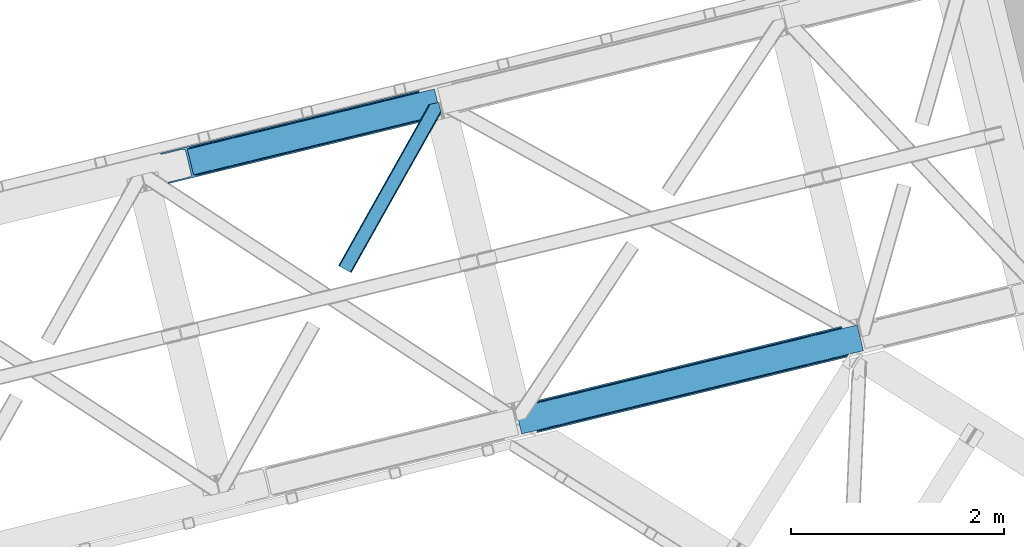
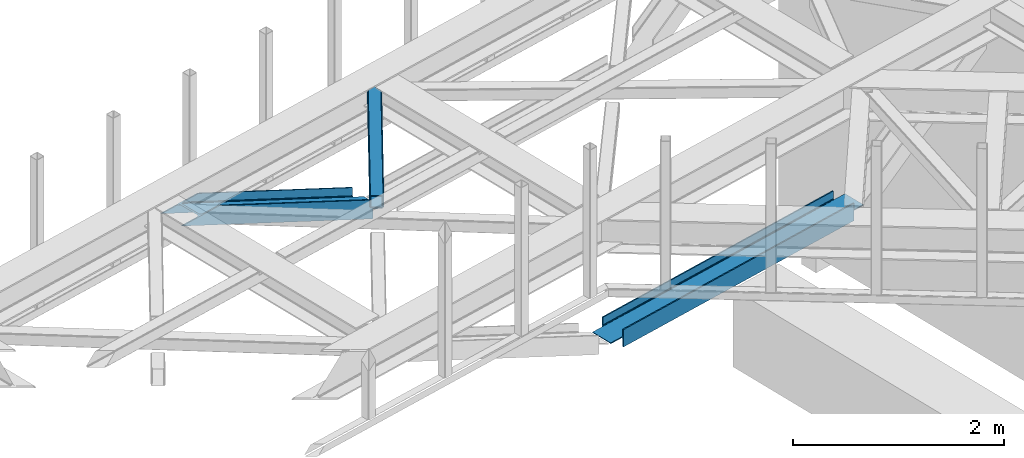
# One storey, part 57 of 66: 3 members.
"""IFC4 building model written with IfcOpenShell, lengths in millimetres."""

import ifcopenshell
import ifcopenshell.guid

model = None  # the IFC model being written
_history = None  # IfcOwnerHistory: only IFC2X3 demands one
_inside = {}  # id of a spatial element -> (the spatial element, [elements in it])
_under = {}  # id of a project, library or spatial element -> (it, [spatial elements below it])
_declared = {}  # id of a project -> (the project, [libraries it declares])
_typed = {}  # id of a type object -> (the type object, [elements of that type])
_made_of = {}  # id of a material, layer set ... -> (it, [elements and type objects made of it])


def new_model(schema):
    """Start an empty IFC model of exactly this schema.

    Asked for "IFC4X3", IfcOpenShell would pick the latest addendum, in which some entities
    have other attributes; the version numbers below select the first issue.
    IFC2X3 requires an IfcOwnerHistory on every rooted entity: one is made here for all.
    """
    global model, _history
    if schema == "IFC4X3":
        model = ifcopenshell.file(schema_version=(4, 3, 0, 0))
    else:
        model = ifcopenshell.file(schema=schema)
    _inside.clear()
    _under.clear()
    _declared.clear()
    _typed.clear()
    _made_of.clear()
    _history = None
    if model.schema == "IFC2X3":
        org = make("IfcOrganization", Name="unknown")
        user = make(
            "IfcPersonAndOrganization",
            ThePerson=make("IfcPerson", FamilyName="unknown"),
            TheOrganization=org,
        )
        app = make(
            "IfcApplication",
            ApplicationDeveloper=org,
            Version="unknown",
            ApplicationFullName="unknown",
            ApplicationIdentifier="unknown",
        )
        _history = make(
            "IfcOwnerHistory",
            OwningUser=user,
            OwningApplication=app,
            ChangeAction="ADDED",
            CreationDate=0,
        )
    return model


def make(cls, **values):
    """One entity of the class cls with the attributes given. An attribute that is None is left unset."""
    return model.create_entity(
        cls, **{name: value for name, value in values.items() if value is not None}
    )


def entity(cls, *values):
    """Any entity or typed value of the class cls, its attributes in the order of the schema. None: left unset."""
    e = model.create_entity(cls)
    for i, value in enumerate(values):
        if value is not None:
            e[i] = value
    return e


def rooted(cls, **values):
    """An entity with a GlobalId (a new one), such as an element, a storey or a relation."""
    return make(cls, GlobalId=ifcopenshell.guid.new(), OwnerHistory=_history, **values)


def si_unit(unit_type, name, prefix=None):
    """IfcSIUnit, for example si_unit("LENGTHUNIT", "METRE", prefix="MILLI")."""
    return make("IfcSIUnit", UnitType=unit_type, Prefix=prefix, Name=name)


def converted_unit(unit_type, name, factor, base, dimensions=None, offset=None):
    """IfcConversionBasedUnit, such as the inch: factor (a typed value) times the base unit."""
    return make(
        "IfcConversionBasedUnit"
        if offset is None
        else "IfcConversionBasedUnitWithOffset",
        ConversionOffset=offset,
        Dimensions=None
        if dimensions is None
        else entity("IfcDimensionalExponents", *dimensions),
        UnitType=unit_type,
        Name=name,
        ConversionFactor=make(
            "IfcMeasureWithUnit", ValueComponent=factor, UnitComponent=base
        ),
    )


def derived_unit(unit_type, elements):
    """IfcDerivedUnit: a product of units, each with its exponent."""
    return make(
        "IfcDerivedUnit",
        Elements=[
            make("IfcDerivedUnitElement", Unit=unit, Exponent=power)
            for unit, power in elements
        ],
        UnitType=unit_type,
    )


def assignment(units):
    """IfcUnitAssignment: the units of a project."""
    return None if units is None else make("IfcUnitAssignment", Units=units)


def point(xyz):
    """IfcCartesianPoint."""
    return None if xyz is None else make("IfcCartesianPoint", Coordinates=xyz)


def direction(xyz):
    """IfcDirection."""
    return None if xyz is None else make("IfcDirection", DirectionRatios=xyz)


def frame(location, z_axis=None, x_axis=None):
    """IfcAxis2Placement3D, a coordinate frame: its origin and axes. An axis left out is left unset."""
    return make(
        "IfcAxis2Placement3D",
        Location=point(location),
        Axis=direction(z_axis),
        RefDirection=direction(x_axis),
    )


def origin():
    """The frame at (0, 0, 0) with its axes left unset."""
    return frame((0.0, 0.0, 0.0))


def place(relative_to, where):
    """IfcLocalPlacement: puts the frame where relative to a parent placement (None: the world)."""
    return make(
        "IfcLocalPlacement", PlacementRelTo=relative_to, RelativePlacement=where
    )


def context(
    kind, dimensions, precision=None, world=None, true_north=None, identifier=None
):
    """IfcGeometricRepresentationContext, for example the 3D "Model" context."""
    return make(
        "IfcGeometricRepresentationContext",
        ContextIdentifier=identifier,
        ContextType=kind,
        CoordinateSpaceDimension=dimensions,
        Precision=precision,
        WorldCoordinateSystem=world,
        TrueNorth=true_north,
    )


def subcontext(parent, identifier, kind, view, scale=None):
    """IfcGeometricRepresentationSubContext, for example "Body" below "Model"."""
    return make(
        "IfcGeometricRepresentationSubContext",
        ContextIdentifier=identifier,
        ContextType=kind,
        ParentContext=parent,
        TargetScale=scale,
        TargetView=view,
    )


def project(units=None, contexts=None):
    """IfcProject with its units and contexts."""
    return rooted(
        "IfcProject",
        Name="project",
        RepresentationContexts=contexts,
        UnitsInContext=assignment(units),
    )


def spatial(cls, under=None, at=None, **own):
    """A site, building, storey or space (cls), placed at a placement, below another one or the project."""
    s = rooted(cls, ObjectPlacement=at, **own)
    if under is not None:
        _under.setdefault(under.id(), (under, []))[1].append(s)
    return s


def point_list(points):
    """IfcCartesianPointList2D or 3D."""
    cls = (
        "IfcCartesianPointList2D" if len(points[0]) == 2 else "IfcCartesianPointList3D"
    )
    return make(cls, CoordList=points)


def triangles(points, corners, closed=None, point_numbers=None):
    """IfcTriangulatedFaceSet: each triangle names its three corners, points numbered from 1."""
    return make(
        "IfcTriangulatedFaceSet",
        Coordinates=point_list(points),
        Closed=closed,
        CoordIndex=corners,
        PnIndex=point_numbers,
    )


def polygons(points, faces, closed=None, point_numbers=None):
    """IfcPolygonalFaceSet: a face is its outer loop, then its inner loops; points numbered from 1."""
    made = []
    for loops in faces:
        if len(loops) == 1:
            made.append(make("IfcIndexedPolygonalFace", CoordIndex=loops[0]))
        else:
            made.append(
                make(
                    "IfcIndexedPolygonalFaceWithVoids",
                    CoordIndex=loops[0],
                    InnerCoordIndices=loops[1:],
                )
            )
    return make(
        "IfcPolygonalFaceSet",
        Coordinates=point_list(points),
        Closed=closed,
        Faces=made,
        PnIndex=point_numbers,
    )


def shape(context_of_items, identifier, shape_type, items):
    """IfcShapeRepresentation: the items that make up one representation, for example the "Body"."""
    return make(
        "IfcShapeRepresentation",
        ContextOfItems=context_of_items,
        RepresentationIdentifier=identifier,
        RepresentationType=shape_type,
        Items=items,
    )


def made_of(thing, what):
    """Note that an element or type object is made of a material, layer set ...; save() writes the relation."""
    if what is not None:
        _made_of.setdefault(what.id(), (what, []))[1].append(thing)
    return thing


def type_object(cls, material=None, **own):
    """A type object (cls), such as IfcWallType, which elements share."""
    return made_of(rooted(cls, **own), material)


def element(
    cls,
    number,
    at=None,
    inside=None,
    cuts=None,
    type_object=None,
    material=None,
    context=None,
    identifier="Body",
    shape_type=None,
    held_by="IfcProductDefinitionShape",
    body=None,
    shapes=None,
    **own,
):
    """One element of the class cls, such as IfcWall. Its Tag is "e" and its number.

    at: its placement. inside: the storey or other place that contains it. cuts: it is an
    opening in that element (IfcRelVoidsElement). A single representation is given by context,
    identifier, shape_type and body (its items); several are given by shapes. held_by: the class
    of the entity that holds the representations. save() writes the other relations.
    """
    e = rooted(cls, Tag="e%d" % number, ObjectPlacement=at, **own)
    if body is not None:
        shapes = [shape(context, identifier, shape_type, body)]
    if shapes is not None:
        e.Representation = make(held_by, Representations=shapes)
    if inside is not None:
        _inside.setdefault(inside.id(), (inside, []))[1].append(e)
    if cuts is not None:
        rooted(
            "IfcRelVoidsElement", RelatingBuildingElement=cuts, RelatedOpeningElement=e
        )
    if type_object is not None:
        _typed.setdefault(type_object.id(), (type_object, []))[1].append(e)
    return made_of(e, material)


def aggregate(whole, parts):
    """IfcRelAggregates: a whole, such as a stair, and the parts it consists of."""
    return rooted("IfcRelAggregates", RelatingObject=whole, RelatedObjects=parts)


def save(model, path):
    """Write the relations noted so far, then the file.

    IfcRelAggregates (storeys below a building ...), IfcRelContainedInSpatialStructure (elements
    in a storey), IfcRelDefinesByType, IfcRelAssociatesMaterial and IfcRelDeclares: one each for
    every whole, place, type object, material and project.
    """
    for whole, parts in _under.values():
        aggregate(whole, parts)
    for where, things in _inside.values():
        rooted(
            "IfcRelContainedInSpatialStructure",
            RelatedElements=things,
            RelatingStructure=where,
        )
    for kind, things in _typed.values():
        rooted("IfcRelDefinesByType", RelatedObjects=things, RelatingType=kind)
    for what, things in _made_of.values():
        rooted("IfcRelAssociatesMaterial", RelatedObjects=things, RelatingMaterial=what)
    for by, libraries in _declared.values():
        rooted("IfcRelDeclares", RelatingContext=by, RelatedDefinitions=libraries)
    model.write(path)


model = new_model("IFC4")

# Units and contexts
model_context = context("Model", 3, precision=0.01, world=origin(), true_north=direction((6.12303176911189e-17, 1.0)))
plan_context = context("Plan", 3, precision=0.01, world=origin(), true_north=direction((6.12303176911189e-17, 1.0)))
body_context = subcontext(model_context, "Body", "Model", "MODEL_VIEW")
ifc_project = project(units=[si_unit("LENGTHUNIT", "METRE", prefix="MILLI"), si_unit("AREAUNIT", "SQUARE_METRE"), si_unit("VOLUMEUNIT", "CUBIC_METRE"), converted_unit("PLANEANGLEUNIT", "DEGREE", entity("IfcRatioMeasure", 0.0174532925199433), si_unit("PLANEANGLEUNIT", "RADIAN"), dimensions=[0, 0, 0, 0, 0, 0, 0]), si_unit("MASSUNIT", "GRAM", prefix="KILO"), derived_unit("MASSDENSITYUNIT", [(si_unit("MASSUNIT", "GRAM", prefix="KILO"), 1), (si_unit("LENGTHUNIT", "METRE"), -3)]), derived_unit("MOMENTOFINERTIAUNIT", [(si_unit("LENGTHUNIT", "METRE"), 4)]), si_unit("TIMEUNIT", "SECOND"), si_unit("FREQUENCYUNIT", "HERTZ"), si_unit("THERMODYNAMICTEMPERATUREUNIT", "DEGREE_CELSIUS"), derived_unit("THERMALTRANSMITTANCEUNIT", [(si_unit("MASSUNIT", "GRAM", prefix="KILO"), 1), (si_unit("THERMODYNAMICTEMPERATUREUNIT", "KELVIN"), -1), (si_unit("TIMEUNIT", "SECOND"), -3)]), derived_unit("VOLUMETRICFLOWRATEUNIT", [(si_unit("LENGTHUNIT", "METRE"), 3), (si_unit("TIMEUNIT", "SECOND"), -1)]), derived_unit("MASSFLOWRATEUNIT", [(si_unit("MASSUNIT", "GRAM", prefix="KILO"), 1), (si_unit("TIMEUNIT", "SECOND"), -1)]), derived_unit("ROTATIONALFREQUENCYUNIT", [(si_unit("TIMEUNIT", "SECOND"), -1)]), si_unit("ELECTRICCURRENTUNIT", "AMPERE"), si_unit("ELECTRICVOLTAGEUNIT", "VOLT"), si_unit("POWERUNIT", "WATT"), si_unit("FORCEUNIT", "NEWTON", prefix="KILO"), si_unit("ILLUMINANCEUNIT", "LUX"), si_unit("LUMINOUSFLUXUNIT", "LUMEN"), si_unit("LUMINOUSINTENSITYUNIT", "CANDELA"), derived_unit("USERDEFINED", [(si_unit("MASSUNIT", "GRAM", prefix="KILO"), -1), (si_unit("LENGTHUNIT", "METRE"), -2), (si_unit("TIMEUNIT", "SECOND"), 3), (si_unit("LUMINOUSFLUXUNIT", "LUMEN"), 1)]), derived_unit("LINEARVELOCITYUNIT", [(si_unit("LENGTHUNIT", "METRE"), 1), (si_unit("TIMEUNIT", "SECOND"), -1)]), si_unit("PRESSUREUNIT", "PASCAL"), derived_unit("USERDEFINED", [(si_unit("LENGTHUNIT", "METRE"), -2), (si_unit("MASSUNIT", "GRAM", prefix="KILO"), 1), (si_unit("TIMEUNIT", "SECOND"), -2)]), derived_unit("LINEARFORCEUNIT", [(si_unit("MASSUNIT", "GRAM", prefix="KILO"), 1), (si_unit("LENGTHUNIT", "METRE"), 1), (si_unit("TIMEUNIT", "SECOND"), -2), (si_unit("LENGTHUNIT", "METRE"), -1)]), derived_unit("PLANARFORCEUNIT", [(si_unit("MASSUNIT", "GRAM", prefix="KILO"), 1), (si_unit("LENGTHUNIT", "METRE"), 1), (si_unit("TIMEUNIT", "SECOND"), -2), (si_unit("LENGTHUNIT", "METRE"), -2)])], contexts=[model_context, plan_context])

# Site, building, storey
site_placement = place(None, origin())
site = spatial("IfcSite", under=ifc_project, at=site_placement, CompositionType="ELEMENT")
building_placement = place(site_placement, origin())
building = spatial("IfcBuilding", under=site, at=building_placement, CompositionType="ELEMENT")
storey_placement = place(building_placement, frame((0.0, 0.0, 19800.0)))
storey = spatial("IfcBuildingStorey", under=building, at=storey_placement, Name="06", CompositionType="ELEMENT", Elevation=19800.0)

# Members
member_type_1 = type_object("IfcMemberType", PredefinedType="BRACE")
member_1_placement = place(storey_placement, frame((-5427.01, 16164.91, 2512.0)))
element("IfcMember", 1, at=member_1_placement, inside=storey, type_object=member_type_1, ObjectType="Steel Vertical Brace", PredefinedType="BRACE", context=body_context, shape_type="Tessellation", body=[
    polygons([(202.213006515028, 24.6242629021892, 77.7499999999953), (597.310843492559, 120.933540718262, 77.7499999999953), (1133.2837289006, 251.582602017929, 77.7499999999953), (1669.25661430864, 382.231663317597, 77.7499999999953), (2205.22949971669, 512.880724617267, 77.7499999999953), (2741.20238512474, 643.529785916936, 77.7499999999953), (3136.30022210225, 739.839063733, 77.7499999999953), (3136.30022210225, 739.839063733003, 0.0), (202.213006515024, 24.6242629021892, 0.0), (3139.37896131113, 727.208886977164, 0.0), (205.291745723898, 11.9940861463507, 0.0), (3139.37896131113, 727.208886977164, 199.999999999998), (205.291745723902, 11.9940861463507, 199.999999999998), (3136.30022210225, 739.839063733, 122.249999999994), (3136.30022210225, 739.839063733, 199.999999999998), (3135.97573046984, 741.170253676399, 84.6383017825712), (3135.0516564821, 744.961161904972, 90.4779220613573), (3133.93196117233, 749.554584314497, 93.8745154964792), (3133.93196117236, 749.554584314421, 106.125484503402), (3135.0516564821, 744.961161904972, 109.522077938641), (3135.97573046984, 741.170253676397, 115.361698217427), (202.213006515032, 24.6242629021914, 122.249999999994), (201.888514882617, 25.955452845588, 115.361698217427), (200.964440894882, 29.7463610741609, 109.522077938641), (199.844745585118, 34.3397834836339, 106.125484503441), (199.844745585125, 34.3397834836079, 93.8745154965962), (200.964440894883, 29.7463610741609, 90.4779220613573), (201.888514882618, 25.9554528455858, 84.6383017825712), (202.213006515032, 24.6242629021914, 199.999999999998), (2634.00780804312, 617.399973657001, 122.249999999994), (1990.84034555346, 460.6211000974, 122.249999999994), (1347.67288306381, 303.842226537796, 122.249999999994), (704.505420574163, 147.063352978195, 122.249999999994), (2738.57084504939, 654.325379189632, 94.3798315850377), (2736.93951545091, 661.017722963484, 95.7499999999999), (3272.91240085895, 791.666784263152, 95.7499999999999), (3274.54373045746, 784.974440489198, 94.3798315851979), (2202.59795964136, 523.676317889856, 94.3798315852023), (2200.96663004286, 530.368661663815, 95.7499999999999), (1666.62507423332, 393.027256590187, 94.3798315852023), (1664.99374463482, 399.719600364147, 95.7499999999999), (1130.65218882528, 262.378195290519, 94.3798315852023), (1129.02085922678, 269.07053906448, 95.7499999999999), (594.679303417238, 131.729133990851, 94.3798315852023), (593.047973818733, 138.421477764808, 95.7499999999999), (58.7064180091808, 1.08007269117741, 94.3798315852023), (57.0750884106749, 7.77241646513577, 95.7499999999999), (2203.98093409654, 518.002822789238, 90.4779220613573), (2739.95381950459, 648.65188408891, 90.4779220613573), (1668.00804868849, 387.353761489571, 90.4779220613573), (1132.03516328045, 256.704700189901, 90.4779220613573), (596.062277872436, 126.055638890127, 90.4779220615175), (2204.90500808427, 514.211914560663, 84.6383017825712), (2740.87789349232, 644.860975860335, 84.6383017825712), (1668.93212267623, 383.562853260996, 84.6383017825712), (1132.95923726819, 252.913791961326, 84.6383017825712), (596.986351860144, 122.264730661659, 84.6383017825712), (58.9696971545974, 6.49720277579036e-12, 93.8745154965962), (3274.80700960288, 783.894367798021, 93.8745154965962), (1990.51585392106, 461.952290040796, 115.361698217427), (2633.68331641071, 618.7311636004, 115.361698217427), (1347.34839143141, 305.173416481193, 115.361698217427), (704.180928941748, 148.394542921592, 115.361698217427), (1989.59177993332, 465.743198269371, 109.522077938641), (2632.75924242298, 622.522071828933, 109.522077938576), (1346.42431744367, 308.964324709768, 109.522077938641), (703.256854954014, 152.185451150165, 109.522077938641), (1988.20880547815, 471.416693369991, 105.620168414796), (2631.3762679678, 628.195566929592, 105.620168414796), (1345.0413429885, 314.637819810388, 105.620168414796), (701.873880498833, 157.858946250822, 105.620168414861), (2629.7449383693, 634.887910703551, 104.249999999998), (3274.54373045746, 784.974440489196, 105.620168414796), (3272.91240085896, 791.666784263154, 104.249999999998), (1986.57747587964, 478.109037143948, 104.249999999998), (1343.41001338999, 321.330163584342, 104.249999999998), (700.242550900337, 164.551290024741, 104.249999999998), (57.0750884106727, 7.77241646513577, 104.249999999998), (58.7064180091862, 1.08007269117957, 105.6201684148), (3274.80700960287, 783.894367798023, 106.125484503402), (58.9696971545974, 0.0, 106.125484503397), (3217.73192119221, 1018.03841381011, 95.7499999999999), (3216.10059159371, 1024.73075758407, 94.3798315852023), (3215.83731244829, 1025.81083027525, 93.8745154965962), (3215.83731244829, 1025.81083027525, 106.125484503397), (3216.10059159371, 1024.73075758407, 105.620168414796), (3217.73192119221, 1018.03841381011, 104.250000000002), (1.8946087439236, 234.144046012098, 104.250000000002), (0.263279145419858, 240.836389786054, 105.620168414796), (1.08286712929839e-12, 241.916462477229, 106.125484503402), (1.08286712929839e-12, 241.916462477229, 93.8745154965962), (0.263279145423107, 240.836389786054, 94.3798315852023), (1.8946087439236, 234.144046012098, 95.7499999999999), (645.062071233588, 390.922919571701, 95.7499999999999), (1288.22953372324, 547.701793131306, 95.7499999999999), (1931.39699621289, 704.480666690907, 95.7499999999999), (2574.56445870255, 861.25954025051, 95.7499999999999), (2681.75903578416, 887.389352510444, 104.250000000002), (2145.78615037611, 756.740291210774, 104.250000000002), (1609.81326496807, 626.091229911109, 104.250000000002), (1073.84037956003, 495.442168611439, 104.250000000002), (537.867494151985, 364.793107311772, 104.250000000002), (1927.45861817149, 720.637413794061, 84.6383017825712), (1927.13412653906, 721.968603737453, 77.7499999999953), (2570.30158902872, 878.747477297058, 77.7499999999953), (2570.62608066114, 877.416287353662, 84.6383017825712), (1284.29115568184, 563.858540234457, 84.6383017825712), (1283.96666404941, 565.189730177852, 77.7499999999953), (641.123693192178, 407.079666674852, 84.6383017825712), (640.799201559762, 408.410856618251, 77.7499999999953), (1928.38269215922, 716.846505565488, 90.4779220613573), (2571.55015464886, 873.625379125128, 90.4779220614179), (1285.21522966957, 560.067632005882, 90.4779220613573), (642.047767179912, 403.288758446281, 90.4779220613573), (1929.76566661439, 711.173010464863, 94.3798315852023), (2572.93312910404, 867.951884024469, 94.3798315852023), (1286.59820412474, 554.394136905262, 94.3798315852023), (643.430741635094, 397.61526334562, 94.3798315851416), (3072.59400308785, 1001.18656737306, 77.7499999999953), (3072.91849472027, 999.855377429661, 84.6383017825712), (3073.84256870799, 996.064469201149, 90.4779220614439), (3074.96226401778, 991.471046791611, 93.8745154965442), (139.755353120758, 280.849668370336, 90.4779220614439), (138.831279133036, 284.64057659885, 84.6383017825712), (138.506787500626, 285.971766542247, 77.7499999999953), (140.875048430543, 276.256245960772, 93.8745154965052), (2680.12770618568, 894.081696284298, 105.620168414956), (2144.15482077761, 763.432634984735, 105.620168414796), (1608.18193536956, 632.783573685067, 105.620168414796), (1072.20904996152, 502.134512385398, 105.620168414796), (536.23616455348, 371.48545108573, 105.620168414796), (2142.77184632243, 769.106130085353, 109.522077938641), (2678.74473173048, 899.755191385027, 109.522077938641), (1606.79896091439, 638.457068785685, 109.522077938641), (1070.82607550635, 507.808007486015, 109.522077938641), (534.853190098281, 377.158946186456, 109.522077938476), (2141.8477723347, 772.897038313926, 115.361698217427), (2677.82065774275, 903.546099613597, 115.361698217427), (1605.87488692666, 642.247977014258, 115.361698217427), (1069.90200151862, 511.598915714588, 115.361698217427), (533.929116110574, 380.949854414921, 115.361698217427), (2141.52328070228, 774.22822825732, 122.249999999994), (2677.49616611034, 904.877289556992, 122.249999999994), (1605.55039529424, 643.579166957652, 122.249999999994), (1069.5775098862, 512.930105657983, 122.249999999994), (533.604624478158, 382.281044358315, 122.249999999994), (3073.84256870796, 996.064469201247, 109.522077938415), (3072.91849472027, 999.855377429664, 115.361698217427), (3072.59400308785, 1001.18656737306, 122.249999999994), (138.50678750063, 285.971766542247, 122.249999999994), (138.831279133041, 284.64057659885, 115.361698217427), (139.755353120736, 280.849668370433, 109.522077938415), (140.875048430552, 276.256245960739, 106.125484503536), (3074.9622640178, 991.471046791488, 106.125484503623), (3072.59400308785, 1001.18656737306, 0.0), (3069.51526387898, 1013.8167441289, 0.0), (3069.51526387898, 1013.8167441289, 199.999999999998), (3072.59400308785, 1001.18656737306, 199.999999999998), (138.506787500632, 285.971766542247, 199.999999999998), (135.428048291757, 298.601943298085, 199.999999999998), (135.428048291757, 298.601943298085, 0.0), (138.506787500632, 285.971766542247, 0.0)], [[[1, 2, 3, 4, 5, 6, 7, 8, 9]], [[9, 8, 10, 11]], [[11, 10, 12, 13]], [[14, 15, 12, 10, 8, 7, 16, 17, 18, 19, 20, 21]], [[22, 23, 24, 25, 26, 27, 28, 1, 9, 11, 13, 29]], [[13, 12, 15, 29]], [[29, 15, 14, 30, 31, 32, 33, 22]], [[34, 35, 36, 37]], [[38, 39, 35, 34]], [[40, 41, 39, 38]], [[42, 43, 41, 40]], [[44, 45, 43, 42]], [[46, 47, 45, 44]], [[48, 38, 34, 49]], [[50, 40, 38, 48]], [[51, 42, 40, 50]], [[52, 44, 42, 51]], [[53, 48, 49, 54]], [[55, 50, 48, 53]], [[56, 51, 50, 55]], [[57, 52, 51, 56]], [[5, 53, 54, 6]], [[4, 55, 53, 5]], [[3, 56, 55, 4]], [[2, 57, 56, 3]], [[17, 16, 54, 49]], [[16, 7, 6, 54]], [[1, 28, 57, 2]], [[28, 27, 52, 57]], [[44, 26, 58, 46]], [[52, 26, 44]], [[26, 52, 27]], [[18, 37, 59]], [[49, 18, 17]], [[34, 18, 49]], [[18, 34, 37]], [[60, 31, 30, 61]], [[62, 32, 31, 60]], [[63, 33, 32, 62]], [[64, 60, 61, 65]], [[66, 62, 60, 64]], [[67, 63, 62, 66]], [[68, 64, 65, 69]], [[70, 66, 64, 68]], [[71, 67, 66, 70]], [[72, 69, 73, 74]], [[75, 68, 69, 72]], [[76, 70, 68, 75]], [[77, 71, 70, 76]], [[78, 79, 71, 77]], [[14, 21, 61, 30]], [[21, 20, 65, 61]], [[69, 19, 80, 73]], [[24, 23, 63, 67]], [[23, 22, 33, 63]], [[25, 79, 81]], [[67, 25, 24]], [[71, 25, 67]], [[25, 71, 79]], [[65, 19, 69]], [[19, 65, 20]], [[19, 18, 59, 80]], [[25, 81, 58, 26]], [[74, 73, 80, 59, 37, 36, 82, 83, 84, 85, 86, 87]], [[47, 46, 58, 81, 79, 78, 88, 89, 90, 91, 92, 93]], [[47, 93, 94, 95, 96, 97, 82, 36, 35, 39, 41, 43, 45]], [[88, 78, 77, 76, 75, 72, 74, 87, 98, 99, 100, 101, 102]], [[103, 104, 105, 106]], [[107, 108, 104, 103]], [[109, 110, 108, 107]], [[111, 103, 106, 112]], [[113, 107, 103, 111]], [[114, 109, 107, 113]], [[115, 111, 112, 116]], [[117, 113, 111, 115]], [[118, 114, 113, 117]], [[97, 116, 83, 82]], [[96, 115, 116, 97]], [[95, 117, 115, 96]], [[94, 118, 117, 95]], [[93, 92, 118, 94]], [[119, 120, 106, 105]], [[120, 121, 112, 106]], [[116, 122, 84, 83]], [[123, 124, 109, 114]], [[124, 125, 110, 109]], [[126, 92, 91]], [[114, 126, 123]], [[118, 126, 114]], [[126, 118, 92]], [[112, 122, 116]], [[122, 112, 121]], [[127, 98, 87, 86]], [[128, 99, 98, 127]], [[129, 100, 99, 128]], [[130, 101, 100, 129]], [[131, 102, 101, 130]], [[89, 88, 102, 131]], [[132, 128, 127, 133]], [[134, 129, 128, 132]], [[135, 130, 129, 134]], [[136, 131, 130, 135]], [[137, 132, 133, 138]], [[139, 134, 132, 137]], [[140, 135, 134, 139]], [[141, 136, 135, 140]], [[142, 137, 138, 143]], [[144, 139, 137, 142]], [[145, 140, 139, 144]], [[146, 141, 140, 145]], [[147, 148, 138, 133]], [[148, 149, 143, 138]], [[150, 151, 141, 146]], [[151, 152, 136, 141]], [[131, 153, 90, 89]], [[136, 153, 131]], [[153, 136, 152]], [[154, 86, 85]], [[133, 154, 147]], [[127, 154, 133]], [[154, 127, 86]], [[85, 84, 122, 154]], [[90, 153, 126, 91]], [[154, 122, 121, 120, 119, 155, 156, 157, 158, 149, 148, 147]], [[153, 152, 151, 150, 159, 160, 161, 162, 125, 124, 123, 126]], [[162, 155, 119, 105, 104, 108, 110, 125]], [[161, 156, 155, 162]], [[150, 146, 145, 144, 142, 143, 149, 158, 159]], [[159, 158, 157, 160]], [[160, 157, 156, 161]]], closed=True),
])
member_type_2 = type_object("IfcMemberType", PredefinedType="BRACE")
member_2_placement = place(storey_placement, frame((-8767.28, 18520.44, 2584.39)))
element("IfcMember", 2, at=member_2_placement, inside=storey, type_object=member_type_2, ObjectType="Steel Vertical Brace", PredefinedType="BRACE", context=body_context, shape_type="Tessellation", body=[
    triangles([(2635.93561706543, 649.181304931641, 33.9583923339851), (2634.040965271, 656.952923583984, 33.9583923339851), (2635.12578277588, 650.127758789062, 32.7096313476541), (2635.1856628418, 648.998757934569, 32.2491943359382), (2635.93561706543, 649.181304931641, 45.3390930175774), (2495.05991363525, 614.841540527344, 97.2405761718728), (2495.05991363525, 614.841540527344, 110.67696533203), (2634.040965271, 656.952923583984, 43.2810791015618), (309.064274597169, 90.2154235839844, 1121.6082824707), (313.935488891602, 84.3134582519524, 1121.6082824707), (2635.65947113037, 650.313793945312, 45.0391113281257), (324.545306396485, 80.8892486572258, 1121.6082824707), (2496.17961273193, 610.247634887695, 114.402319335935), (2497.10397491455, 606.457168579102, 120.806579589844), (339.278128051759, 80.4636932373032, 1121.6082824707), (2497.42837371826, 605.125854492188, 128.361932373045), (355.89223022461, 83.1030670166001, 1121.6082824707), (2497.42837371826, 605.125854492188, 213.642773437499), (539.761820983887, 127.923587036134, 1121.6082824707), (2500.5072555542, 592.495230102541, 213.642773437499), (542.840702819825, 115.29412536621, 1121.6082824707), (2578.86061248779, 883.325152587891, 43.2810791015618), (253.883921813966, 316.587652587892, 1121.6082824707), (2500.5072555542, 592.495230102541, 2.47891845702907), (2497.42837371826, 605.125854492188, 79.5532836914063), (2497.42837371826, 605.125854492188, 2.47891845702907), (2497.10397491455, 606.457168579102, 87.1086364746079), (2496.17961273193, 610.247634887695, 93.5152221679673), (287.352809143067, 77.833621215821, 1121.6082824707), (279.509101867676, 69.9108489990249, 1121.6082824707), (288.961431884767, 85.3157226562507, 1121.6082824707), (266.619772338869, 62.7531463623054, 1121.6082824707), (250.655049133302, 57.4511444091804, 1121.6082824707), (2488.16672973633, 589.487274169922, 0.0), (69.8637588500987, 0.0, 1121.6082824707), (2485.08784790039, 602.117898559569, 0.0), (66.7848770141609, 12.630624389647, 1121.6082824707), (2578.86061248779, 883.325152587891, 33.9583923339851), (233.781079101564, 311.686788940431, 1121.6082824707), (2576.96596069336, 891.097933959962, 33.9583923339851), (2577.24210662842, 889.964282226563, 45.0391113281257), (2576.96596069336, 891.097933959962, 45.3390930175774), (2576.68225708008, 889.884054565431, 32.7096313476541), (2576.21600646973, 890.914224243163, 32.2491943359382), (2436.09025726318, 856.758169555666, 97.2405761718728), (2436.09025726318, 856.758169555666, 110.67696533203), (255.492544555666, 324.069754028322, 1121.6082824707), (263.336251831055, 331.992526245118, 1121.6082824707), (2434.9705581665, 861.350912475587, 114.402319335935), (2434.04677734375, 865.141378784181, 120.806579589844), (276.220930480958, 339.14906616211, 1121.6082824707), (2433.72237854004, 866.472692871095, 128.361932373045), (292.186235046387, 344.451068115235, 1121.6082824707), (2434.9705581665, 861.350912475587, 93.5152221679673), (228.90986480713, 317.589916992187, 1121.6082824707), (218.300047302248, 321.014126586913, 1121.6082824707), (2433.72237854004, 866.472692871095, 79.5532836914063), (2434.04677734375, 865.141378784181, 87.1086364746079), (203.562574768068, 321.437356567381, 1121.6082824707), (186.948472595215, 318.797982788084, 1121.6082824707), (2433.72237854004, 866.472692871095, 213.642773437499), (476.055825805664, 389.271588134765, 1121.6082824707), (2430.6434967041, 879.103317260742, 213.642773437499), (472.976943969727, 401.901049804688, 1121.6082824707), (0.0, 286.608087158202, 1121.6082824707), (3.07888183593786, 273.978625488282, 1121.6082824707), (2430.6434967041, 879.103317260742, 2.47891845702907), (2433.72237854004, 866.472692871095, 2.47891845702907), (2418.30297088623, 876.095361328124, 0.0), (2421.38185272217, 863.464736938477, 0.0)], [[1, 2, 3], [3, 4, 1], [4, 5, 6], [5, 4, 1], [7, 6, 5], [8, 9, 10], [11, 10, 7], [7, 10, 12], [12, 13, 7], [7, 5, 11], [14, 13, 15], [12, 15, 13], [16, 14, 17], [15, 17, 14], [10, 11, 8], [18, 16, 19], [17, 19, 16], [20, 18, 19], [19, 21, 20], [8, 22, 23], [23, 9, 8], [24, 25, 16], [26, 25, 24], [16, 25, 14], [16, 20, 24], [18, 20, 16], [14, 25, 27], [27, 28, 13], [28, 6, 13], [7, 13, 6], [13, 14, 27], [29, 3, 6], [6, 30, 29], [6, 28, 30], [3, 4, 6], [2, 3, 31], [29, 31, 3], [28, 27, 30], [32, 30, 27], [27, 25, 32], [33, 32, 25], [34, 20, 21], [20, 34, 24], [21, 35, 34], [25, 36, 33], [25, 26, 36], [37, 33, 36], [36, 34, 35], [35, 37, 36], [26, 24, 36], [34, 36, 24], [38, 2, 39], [31, 39, 2], [22, 38, 8], [40, 22, 41], [22, 40, 38], [41, 42, 40], [2, 8, 38], [8, 1, 11], [1, 8, 2], [5, 11, 1], [38, 40, 43], [44, 43, 40], [42, 44, 45], [42, 40, 44], [45, 46, 42], [47, 41, 46], [46, 48, 47], [46, 49, 48], [41, 42, 46], [22, 41, 47], [47, 23, 22], [49, 50, 51], [51, 48, 49], [50, 52, 53], [53, 51, 50], [54, 45, 55], [55, 56, 54], [57, 58, 59], [59, 60, 57], [58, 54, 56], [56, 59, 58], [44, 43, 45], [55, 45, 43], [43, 38, 39], [39, 55, 43], [52, 61, 62], [62, 53, 52], [61, 63, 62], [64, 62, 63], [9, 23, 31], [48, 51, 59], [53, 64, 65], [62, 64, 53], [51, 53, 60], [23, 47, 55], [47, 48, 56], [12, 32, 15], [21, 17, 35], [17, 15, 33], [21, 19, 17], [12, 10, 30], [10, 9, 29], [31, 23, 39], [60, 59, 51], [55, 47, 56], [59, 56, 48], [55, 39, 23], [65, 60, 53], [65, 66, 60], [33, 15, 32], [30, 10, 29], [31, 29, 9], [30, 32, 12], [33, 35, 17], [35, 33, 37], [50, 58, 57], [45, 54, 49], [54, 58, 49], [50, 49, 58], [49, 46, 45], [57, 67, 52], [67, 57, 68], [63, 52, 67], [57, 52, 50], [63, 61, 52], [63, 69, 64], [63, 67, 69], [65, 64, 69], [70, 57, 60], [57, 70, 68], [60, 66, 70], [69, 70, 66], [66, 65, 69], [67, 68, 70], [70, 69, 67]]),
])
member_type_3 = type_object("IfcMemberType", PredefinedType="BRACE")
member_3_placement = place(storey_placement, frame((-7093.95, 17681.05, 3823.0)))
element("IfcMember", 3, at=member_3_placement, inside=storey, type_object=member_type_3, ObjectType="Steel Horizontal Brace", PredefinedType="BRACE", context=body_context, shape_type="Tessellation", body=[
    triangles([(963.930697631836, 1521.10947875976, 138.668280029298), (961.605839538574, 1530.64726867676, 140.00075683594), (106.81092224121, 8.56924438476563, 140.00075683594), (112.646612548828, 5.28921203613208, 138.668280029298), (965.901507568359, 1513.02392578125, 134.87548828125), (117.598635864258, 2.50914916992042, 134.87548828125), (967.218287658691, 1507.62192993164, 129.196765136719), (120.904829406738, 0.651123046875, 129.196765136719), (967.681050109863, 1505.72553405762, 122.499499511719), (122.068711853027, 0.0, 122.499499511719), (967.681050109863, 1505.72553405762, 17.5012573242202), (122.068711853027, 0.0, 17.5012573242202), (15.2577896118164, 59.9835479736321, 140.00075683594), (873.405990600586, 1588.02516174316, 140.00075683594), (943.45694732666, 1605.10086364746, 140.00075683594), (851.920092773437, 1582.787109375, 129.196765136719), (850.14868927002, 1582.35574035644, 122.499499511719), (1.15981292724609, 67.8993438720681, 129.196765136719), (0.0, 68.5527923583977, 122.499499511719), (856.962808227539, 1584.0172668457, 134.87548828125), (4.47007598876917, 66.04248046875, 134.87548828125), (864.504208374024, 1585.8555267334, 138.668280029298), (9.41802978515625, 63.2624176025383, 138.668280029298), (850.14868927002, 1582.35574035644, 17.5012573242202), (0.0, 68.5527923583977, 17.5012573242202), (1.15981292724609, 67.8993438720681, 10.8039916992202), (851.920092773437, 1582.787109375, 10.8039916992202), (810.913293457031, 1502.80361938477, 5.52059326172093), (4.47007598876917, 66.04248046875, 5.12526855468968), (810.772023010254, 1501.75252075195, 5.13457031250073), (856.451792907715, 1583.89285583496, 5.52059326172093), (810.640054321289, 1500.7432800293, 4.76482543945531), (810.549362182617, 1500.07355346679, 4.52065429687718), (9.41802978515625, 63.2624176025383, 1.33247680664135), (812.299255371094, 1492.894921875, 1.33247680664135), (814.624113464355, 1483.35829467773, 0.0), (15.2577896118164, 59.9835479736321, 0.0), (842.022441101074, 1370.95817871093, 0.0), (106.81092224121, 8.56924438476563, 0.0), (876.666256713867, 1379.40301208496, 0.0), (893.620454406738, 1383.53648071289, 5.52059326172093), (885.56803894043, 1381.57264709473, 1.33247680664135), (842.993893432617, 1371.19537353516, 5.52059326172093), (842.022441101074, 1370.95817871093, 4.52065429687718), (117.598635864258, 2.50914916992042, 5.12526855468968), (112.646612548828, 5.28921203613208, 1.33247680664135), (966.000920104981, 1506.03830566406, 10.9621215820334), (120.904829406738, 0.651123046875, 10.8039916992202), (967.429902648925, 1506.75570373535, 12.5201660156272), (961.010527038574, 1503.53380737305, 5.52059326172093), (936.65678100586, 1603.44282531738, 5.52059326172093), (963.604554748535, 1522.44893188476, 12.5201660156272), (958.492657470703, 1525.72547607422, 8.3320495605476), (955.213787841797, 1533.55988159179, 6.99957275390625), (938.093321228027, 1603.79280395508, 6.99957275390625), (21.3638122558596, 56.5558502197237, 6.99957275390625), (882.70484161377, 1590.29130249023, 6.99957275390625), (100.704899597168, 11.9957794189431, 6.99957275390625), (111.497264099121, 5.9380096435525, 12.1248413085959), (114.803457641601, 4.07998352050708, 17.8035644531265), (964.788784790039, 1517.59108886719, 17.8035644531265), (106.544659423828, 8.71690979003688, 8.3320495605476), (965.250965881348, 1515.69353027343, 24.5008300781265), (115.962689208985, 3.4265350341775, 24.5008300781265), (965.250965881348, 1515.69353027343, 115.499926757813), (115.962689208985, 3.4265350341775, 115.499926757813), (964.788784790039, 1517.59108886719, 122.197192382813), (963.472004699707, 1522.9930847168, 127.873590087893), (961.50061340332, 1531.07863769531, 131.668707275392), (959.176336669922, 1540.61526489258, 133.001184082033), (943.45694732666, 1605.10086364746, 133.001184082033), (114.803457641601, 4.07998352050708, 122.197192382813), (111.497264099121, 5.9380096435525, 127.873590087893), (106.544659423828, 8.71690979003688, 131.668707275392), (100.704899597168, 11.9957794189431, 133.001184082033), (21.3638122558596, 56.5558502197237, 133.001184082033), (882.70484161377, 1590.29130249023, 133.001184082033), (10.5714477539059, 62.6147827148416, 127.873590087893), (15.5240524291994, 59.8347198486299, 131.668707275392), (6.10137176513672, 65.1239318847656, 115.499926757813), (7.2652542114256, 64.4728088378906, 122.197192382813), (10.5714477539059, 62.6147827148416, 12.1248413085959), (15.5240524291994, 59.8347198486299, 8.3320495605476), (6.10137176513672, 65.1239318847656, 24.5008300781265), (7.2652542114256, 64.4728088378906, 17.8035644531265), (873.807710266113, 1588.12283020019, 131.668707275392), (866.261659240722, 1586.28340759277, 127.873590087893), (861.223594665527, 1585.05557556152, 122.197192382813), (859.45219116211, 1584.62420654297, 115.499926757813), (873.807710266113, 1588.12283020019, 8.3320495605476), (861.223594665527, 1585.05557556152, 17.8035644531265), (866.261659240722, 1586.28340759277, 12.1248413085959), (859.45219116211, 1584.62420654297, 24.5008300781265)], [[1, 2, 3], [3, 4, 1], [5, 1, 4], [4, 6, 5], [7, 5, 6], [6, 8, 7], [9, 7, 8], [8, 10, 9], [11, 9, 12], [10, 12, 9], [13, 2, 14], [13, 3, 2], [2, 15, 14], [16, 17, 18], [19, 18, 17], [20, 16, 21], [18, 21, 16], [22, 20, 23], [21, 23, 20], [14, 22, 13], [23, 13, 22], [17, 24, 19], [25, 19, 24], [26, 27, 28], [28, 29, 26], [28, 30, 29], [27, 31, 28], [29, 30, 32], [33, 34, 29], [33, 35, 34], [35, 36, 34], [37, 34, 36], [24, 27, 26], [26, 25, 24], [38, 37, 36], [39, 38, 40], [38, 39, 37], [40, 41, 42], [40, 38, 43], [40, 43, 41], [43, 38, 44], [36, 33, 44], [36, 35, 33], [44, 38, 36], [45, 46, 42], [47, 48, 41], [48, 45, 41], [12, 48, 47], [47, 49, 12], [49, 11, 12], [41, 50, 47], [42, 41, 45], [40, 42, 46], [46, 39, 40], [41, 28, 50], [41, 43, 28], [31, 50, 28], [51, 50, 31], [52, 50, 53], [49, 47, 52], [52, 47, 50], [54, 50, 51], [50, 54, 53], [51, 55, 54], [56, 54, 57], [56, 58, 54], [54, 55, 57], [59, 60, 61], [61, 52, 59], [62, 59, 52], [53, 54, 58], [58, 62, 53], [52, 53, 62], [63, 61, 60], [60, 64, 63], [65, 63, 64], [64, 66, 65], [61, 49, 52], [9, 11, 63], [11, 61, 63], [63, 65, 9], [11, 49, 61], [67, 9, 65], [7, 9, 67], [5, 67, 68], [67, 5, 7], [68, 1, 5], [69, 1, 68], [69, 70, 2], [69, 2, 1], [70, 15, 2], [70, 71, 15], [67, 65, 72], [66, 72, 65], [68, 67, 73], [72, 73, 67], [69, 68, 74], [73, 74, 68], [70, 69, 75], [74, 75, 69], [76, 70, 75], [70, 76, 77], [71, 70, 77], [8, 73, 72], [66, 12, 10], [8, 72, 10], [8, 6, 73], [72, 66, 10], [73, 6, 4], [75, 3, 13], [3, 74, 4], [74, 3, 75], [74, 73, 4], [48, 59, 45], [64, 12, 66], [12, 60, 48], [60, 12, 64], [48, 60, 59], [39, 58, 37], [46, 45, 59], [59, 62, 46], [62, 58, 39], [39, 46, 62], [78, 23, 21], [13, 76, 75], [13, 79, 76], [79, 13, 23], [78, 79, 23], [80, 19, 25], [18, 81, 78], [21, 18, 78], [81, 18, 19], [80, 81, 19], [34, 82, 29], [37, 58, 56], [56, 83, 37], [83, 82, 34], [34, 37, 83], [26, 29, 82], [25, 84, 80], [85, 25, 26], [25, 85, 84], [85, 26, 82], [22, 14, 86], [15, 77, 14], [77, 15, 71], [77, 86, 14], [87, 22, 86], [87, 20, 22], [20, 88, 16], [88, 20, 87], [17, 88, 89], [88, 17, 16], [57, 31, 90], [91, 92, 31], [92, 90, 31], [57, 51, 31], [51, 57, 55], [93, 91, 24], [27, 24, 91], [17, 93, 24], [93, 17, 89], [91, 31, 27], [91, 93, 85], [84, 85, 93], [92, 91, 82], [85, 82, 91], [90, 92, 83], [82, 83, 92], [57, 90, 56], [83, 56, 90], [93, 89, 84], [80, 84, 89], [86, 77, 76], [76, 79, 86], [87, 86, 79], [79, 78, 87], [88, 87, 78], [78, 81, 88], [89, 88, 81], [81, 80, 89]]),
])

save(model, "model.ifc")
